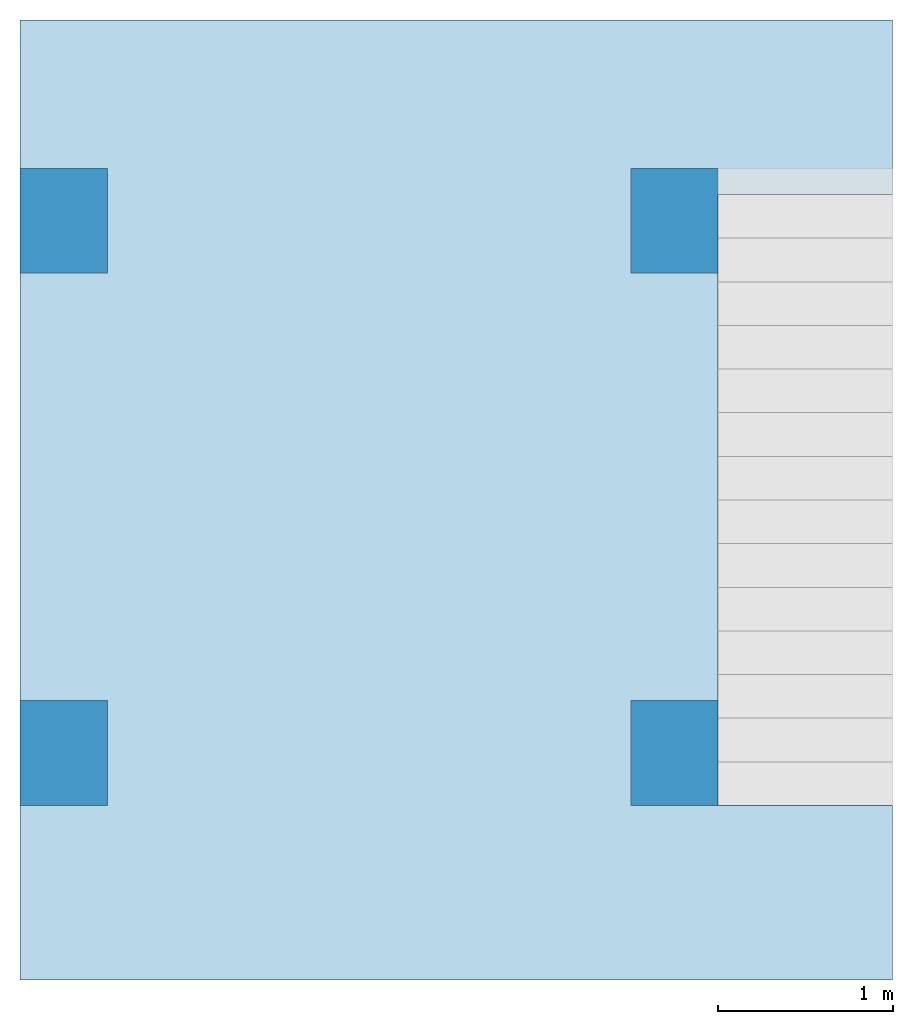
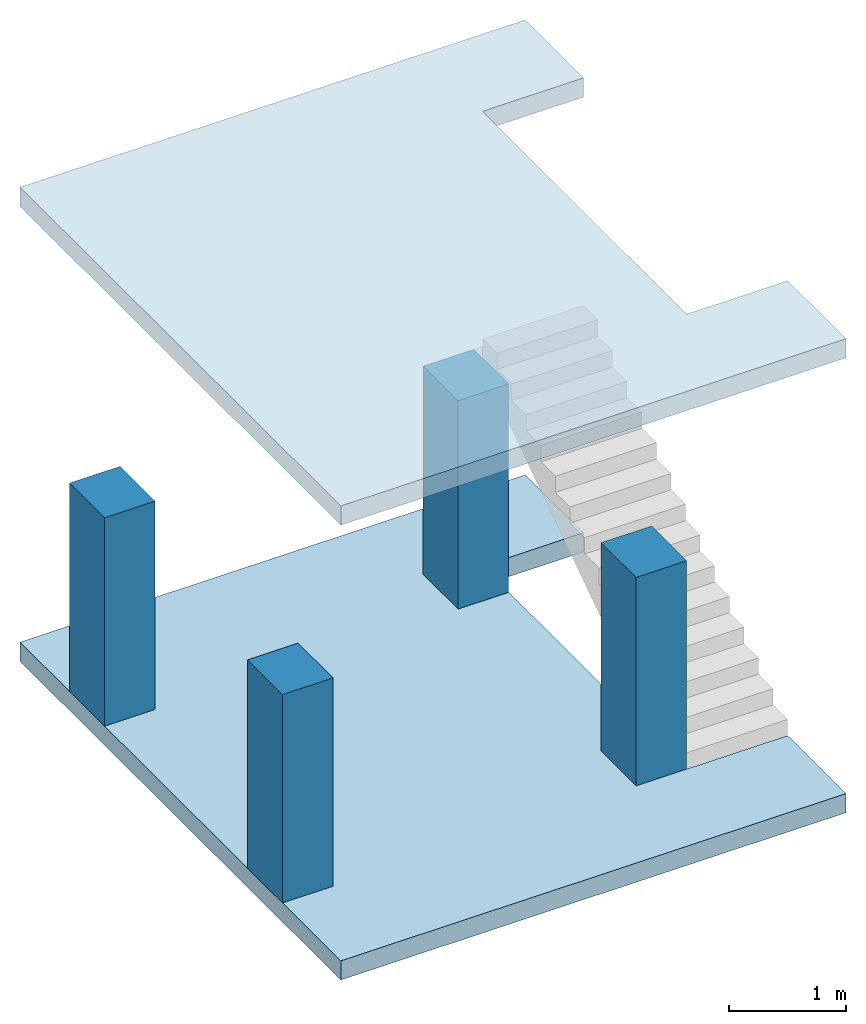
# One storey, part 1 of 2: 4 columns, 2 slabs.
"""IFC4 building model written with IfcOpenShell, lengths in millimetres."""

from ifc_helpers import new_model, entity, si_unit, converted_unit, frame, origin_with_axes, origin_2d_with_axis, place, context, subcontext, project, spatial, line, indexed_curve, rectangle, outline, extrude, material, layer, layer_set, layer_usage, material_profile, profile_set, profile_usage, type_object, element, save


model = new_model("IFC4")

# Units and contexts
model_context = context("Model", 3, precision=1e-05, world=origin_with_axes())
plan_context = context("Plan", 2, precision=1e-05, world=origin_2d_with_axis())
body_context = subcontext(model_context, "Body", "Model", "MODEL_VIEW")
ifc_project = project(units=[si_unit("VOLUMEUNIT", "CUBIC_METRE", prefix="MILLI"), si_unit("LENGTHUNIT", "METRE", prefix="MILLI"), converted_unit("PLANEANGLEUNIT", "degree", entity("IfcReal", 0.0174532925199433), si_unit("PLANEANGLEUNIT", "RADIAN"), dimensions=[0, 0, 0, 0, 0, 0, 0]), si_unit("AREAUNIT", "SQUARE_METRE", prefix="MILLI")], contexts=[model_context, plan_context])

# Site, building, storey
site_placement = place(None, origin_with_axes())
site = spatial("IfcSite", under=ifc_project, at=site_placement)
building_placement = place(site_placement, origin_with_axes())
building = spatial("IfcBuilding", under=site, at=building_placement, Name="Building")
storey_placement = place(building_placement, origin_with_axes())
storey = spatial("IfcBuildingStorey", under=building, at=storey_placement, Name="Storey")

# Columns
ifc_material = material()
ifc_material_profile = material_profile(ifc_material, rectangle(XDim=500.0, YDim=600.0))
ifc_profile_set = profile_set([ifc_material_profile])
ifc_profile_usage_1 = profile_usage(ifc_profile_set, cardinal=5)
column_type = type_object("IfcColumnType", Name="C1", PredefinedType="NOTDEFINED", material=ifc_profile_set)
column_1_placement = place(storey_placement, frame((3750.0, 4350.47721862793, 0.0), z_axis=(0.0, 0.0, 1.0), x_axis=(1.0, 0.0, 0.0)))
element("IfcColumn", 1, at=column_1_placement, inside=storey, type_object=column_type, material=ifc_profile_usage_1, Name="Column", PredefinedType="NOTDEFINED", context=body_context, shape_type="SweptSolid", body=[
    extrude(rectangle(XDim=500.0, YDim=600.0), origin_with_axes(), (0.0, 0.0, 1.0), 2180.00031007537),
])
ifc_profile_usage_2 = profile_usage(ifc_profile_set, cardinal=5)
column_2_placement = place(storey_placement, frame((3750.0, 1300.00019073486, 0.0), z_axis=(0.0, 0.0, 1.0), x_axis=(1.0, 0.0, 0.0)))
element("IfcColumn", 2, at=column_2_placement, inside=storey, type_object=column_type, material=ifc_profile_usage_2, Name="Column", PredefinedType="NOTDEFINED", context=body_context, shape_type="SweptSolid", body=[
    extrude(rectangle(XDim=500.0, YDim=600.0), origin_with_axes(), (0.0, 0.0, 1.0), 2180.00031007537),
])
ifc_profile_usage_3 = profile_usage(ifc_profile_set, cardinal=5)
column_3_placement = place(storey_placement, frame((250.0, 4350.47721862793, 0.0), z_axis=(0.0, 0.0, 1.0), x_axis=(1.0, 0.0, 0.0)))
element("IfcColumn", 3, at=column_3_placement, inside=storey, type_object=column_type, material=ifc_profile_usage_3, Name="Column", PredefinedType="NOTDEFINED", context=body_context, shape_type="SweptSolid", body=[
    extrude(rectangle(XDim=500.0, YDim=600.0), origin_with_axes(), (0.0, 0.0, 1.0), 2180.00009134275),
])
ifc_profile_usage_4 = profile_usage(ifc_profile_set, cardinal=5)
column_4_placement = place(storey_placement, frame((250.0, 1300.00019073486, 0.0), z_axis=(0.0, 0.0, 1.0), x_axis=(1.0, 0.0, 0.0)))
element("IfcColumn", 4, at=column_4_placement, inside=storey, type_object=column_type, material=ifc_profile_usage_4, Name="Column", PredefinedType="NOTDEFINED", context=body_context, shape_type="SweptSolid", body=[
    extrude(rectangle(XDim=500.0, YDim=600.0), origin_with_axes(), (0.0, 0.0, 1.0), 2180.00009134275),
])

# Slabs
ifc_layer = layer(ifc_material, 200.0)
ifc_layer_set = layer_set([ifc_layer])
ifc_layer_usage_1 = layer_usage(ifc_layer_set, "AXIS3", "POSITIVE", 0.0)
slab_type = type_object("IfcSlabType", Name="FLR150", PredefinedType="NOTDEFINED", material=ifc_layer_set)
slab_1_placement = place(storey_placement, frame((0.0, 0.0, -200.000002980232), z_axis=(0.0, 0.0, 1.0), x_axis=(1.0, 0.0, 0.0)))
element("IfcSlab", 5, at=slab_1_placement, inside=storey, type_object=slab_type, material=ifc_layer_usage_1, Name="Slab", PredefinedType="NOTDEFINED", context=body_context, shape_type="SweptSolid", body=[
    extrude(outline(indexed_curve([(0.0, 0.0), (5000.0, 0.0), (5000.0, 5500.0), (0.0, 5500.0), (5000.0, 4500.0), (5000.0, 1000.0), (4000.0, 4500.0), (4000.0, 1000.0)], segments=[line(6, 2), line(2, 1), line(1, 4), line(4, 3), line(3, 5), line(5, 7), line(7, 8), line(8, 6)], self_intersect=False)), None, (0.0, 0.0, 1.0), 200.0),
])
ifc_layer_usage_2 = layer_usage(ifc_layer_set, "AXIS3", "POSITIVE", 0.0)
slab_2_placement = place(storey_placement, frame((0.0, 0.0, 4560.0004196167), z_axis=(0.0, 0.0, 1.0), x_axis=(1.0, 0.0, 0.0)))
element("IfcSlab", 6, at=slab_2_placement, inside=storey, type_object=slab_type, material=ifc_layer_usage_2, Name="Slab", PredefinedType="NOTDEFINED", context=body_context, shape_type="SweptSolid", body=[
    extrude(outline(indexed_curve([(0.0, 0.0), (5000.0, 0.0), (5000.0, 5500.0), (0.0, 5500.0), (5000.0, 4500.0), (5000.0, 1000.0), (4000.0, 4500.0), (4000.0, 1000.0)], segments=[line(6, 2), line(2, 1), line(1, 4), line(4, 3), line(3, 5), line(5, 7), line(7, 8), line(8, 6)], self_intersect=False)), None, (0.0, 0.0, 1.0), 200.0),
])

save(model, "model.ifc")
